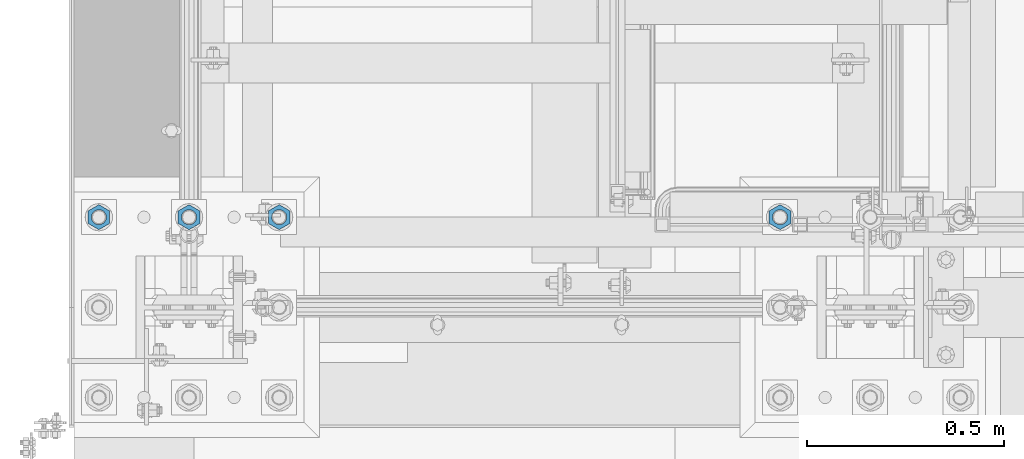
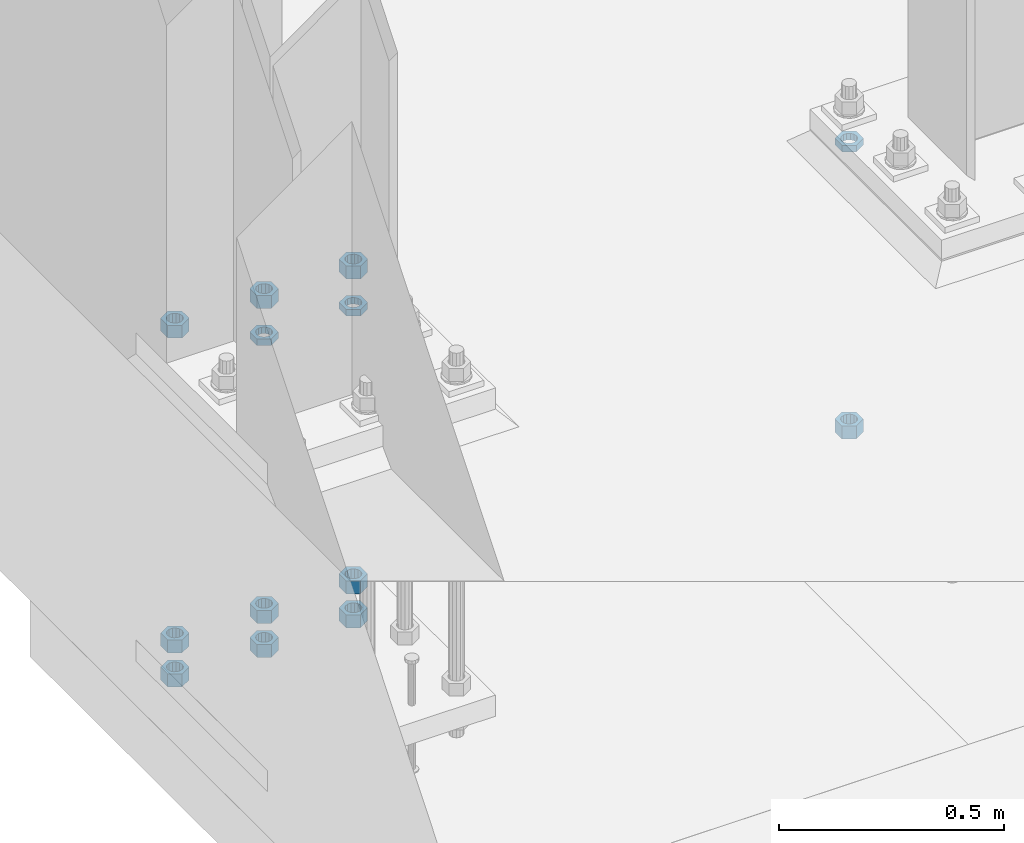
# One storey, part 1383 of 1876: 13 beams, 2 elements without a shape of their own.
"""IFC2X3 building model written with IfcOpenShell, lengths in millimetres."""

from ifc_helpers import new_model, si_unit, frame, origin_with_axes, place, context, subcontext, project, spatial, faceted_brep, material, type_object, element, aggregate, save


model = new_model("IFC2X3")

# Units and contexts
model_context = context("Model", 3, precision=1e-05, world=origin_with_axes())
body_context = subcontext(model_context, "Body", "Model", "MODEL_VIEW")
ifc_project = project(units=[si_unit("LENGTHUNIT", "METRE", prefix="MILLI"), si_unit("AREAUNIT", "SQUARE_METRE"), si_unit("VOLUMEUNIT", "CUBIC_METRE"), si_unit("MASSUNIT", "GRAM", prefix="KILO"), si_unit("TIMEUNIT", "SECOND"), si_unit("PLANEANGLEUNIT", "RADIAN"), si_unit("SOLIDANGLEUNIT", "STERADIAN"), si_unit("THERMODYNAMICTEMPERATUREUNIT", "DEGREE_CELSIUS"), si_unit("LUMINOUSINTENSITYUNIT", "LUMEN")], contexts=[model_context])

# Site, building, storey
site_placement = place(None, origin_with_axes())
site = spatial("IfcSite", under=ifc_project, at=site_placement, CompositionType="ELEMENT")
building_placement = place(site_placement, origin_with_axes())
building = spatial("IfcBuilding", under=site, at=building_placement, Name="Undefined", CompositionType="ELEMENT")
storey_placement = place(building_placement, origin_with_axes())
storey = spatial("IfcBuildingStorey", under=building, at=storey_placement, Name="Undefined", CompositionType="ELEMENT", Elevation=0.0)

# Assembly, beam
assembly_1_placement = place(storey_placement, origin_with_axes())
assembly_1 = element("IfcElementAssembly", 1, at=assembly_1_placement, inside=storey, Name="TEMPLATE", AssemblyPlace="NOTDEFINED", PredefinedType="RIGID_FRAME")
ifc_material = material(Name="STEEL/A563")
beam_type_1 = type_object("IfcBeamType", Name="1-3/8_DIA. HALF_NUT", PredefinedType="NOTDEFINED")
beam_1_placement = place(assembly_1_placement, frame((1498.6, -6883.4, 33.3375), z_axis=(-1.0, 0.0, 0.0), x_axis=(0.0, 0.0, -1.0)))
beam_1 = element("IfcBeam", 2, at=beam_1_placement, type_object=beam_type_1, material=ifc_material, Name="NUT", ObjectType="1-3/8_DIA. HALF_NUT", context=body_context, shape_type="Brep", body=[
    faceted_brep([(0.0, -31.75, 0.0), (0.0, -15.8800001144409, -27.5), (17.4625, -15.8800001144409, -27.5), (17.4625, -31.75, 0.0), (0.0, 15.8800001144409, -27.5), (17.4625, 15.8800001144409, -27.5), (0.0, 31.75, 0.0), (17.4625, 31.75, 0.0), (0.0, 15.8800001144409, 27.5), (17.4625, 15.8800001144409, 27.5), (0.0, -15.8800001144409, 27.5), (17.4625, -15.8800001144409, 27.5), (0.0, 0.0, 19.0499999999993), (0.0, 8.2654848991624, 17.1634562461559), (17.4625, 8.2654848991624, 17.1634562461559), (17.4625, 0.0, 19.0499992370605), (0.0, 14.8938891445259, 11.8774802497237), (17.4625, 14.8938891445259, 11.8774802497237), (0.0, 18.5723759832526, 4.2390236220981), (17.4625, 18.5723759832526, 4.2390236220981), (0.0, 18.5723759832526, -4.2390236220981), (17.4625, 18.5723759832526, -4.2390236220981), (0.0, 14.8938891445259, -11.8774802497237), (17.4625, 14.8938891445259, -11.8774802497237), (0.0, 8.2654848991624, -17.1634562461568), (17.4625, 8.2654848991624, -17.1634562461568), (0.0, 0.0, -19.05), (17.4625, 0.0, -19.0499992370605), (0.0, -8.2654848991624, -17.1634562461559), (17.4625, -8.2654848991624, -17.1634562461559), (0.0, -14.8938891445259, -11.8774802497237), (17.4625, -14.8938891445259, -11.8774802497237), (0.0, -18.5723759832526, -4.2390236220981), (17.4625, -18.5723759832526, -4.2390236220981), (0.0, -18.5723759832526, 4.2390236220981), (17.4625, -18.5723759832526, 4.2390236220981), (0.0, -14.8938891445259, 11.8774802497237), (17.4625, -14.8938891445259, 11.8774802497237), (0.0, -8.2654848991624, 17.1634562461568), (17.4625, -8.2654848991624, 17.1634562461568)], [[[0, 1, 2, 3]], [[1, 4, 5, 2]], [[4, 6, 7, 5]], [[6, 8, 9, 7]], [[8, 10, 11, 9]], [[10, 0, 3, 11]], [[12, 13, 14, 15]], [[13, 16, 17, 14]], [[16, 18, 19, 17]], [[18, 20, 21, 19]], [[20, 22, 23, 21]], [[22, 24, 25, 23]], [[24, 26, 27, 25]], [[26, 28, 29, 27]], [[28, 30, 31, 29]], [[30, 32, 33, 31]], [[32, 34, 35, 33]], [[34, 36, 37, 35]], [[36, 38, 39, 37]], [[38, 12, 15, 39]], [[5, 7, 9, 11, 3, 2], [17, 19, 21, 23, 25, 27, 29, 31, 33, 35, 37, 39, 15, 14]], [[10, 8, 6, 4, 1, 0], [38, 36, 34, 32, 30, 28, 26, 24, 22, 20, 18, 16, 13, 12]]]),
])

# Assembly, beams
assembly_2_placement = place(storey_placement, origin_with_axes())
assembly_2 = element("IfcElementAssembly", 3, at=assembly_2_placement, inside=storey, Name="TEMPLATE", AssemblyPlace="NOTDEFINED", PredefinedType="RIGID_FRAME")
beam_2_placement = place(assembly_2_placement, frame((-2.27373675443232e-13, -6883.4, 33.3375), z_axis=(-1.0, 0.0, 0.0), x_axis=(0.0, 0.0, -1.0)))
beam_2 = element("IfcBeam", 4, at=beam_2_placement, type_object=beam_type_1, material=ifc_material, Name="NUT", ObjectType="1-3/8_DIA. HALF_NUT", context=body_context, shape_type="Brep", body=[
    faceted_brep([(0.0, -31.75, 0.0), (0.0, -15.8800001144409, -27.5), (17.4625, -15.8800001144409, -27.5), (17.4625, -31.75, 0.0), (0.0, 15.8800001144409, -27.5), (17.4625, 15.8800001144409, -27.5), (0.0, 31.75, 0.0), (17.4625, 31.75, 0.0), (0.0, 15.8800001144409, 27.5), (17.4625, 15.8800001144409, 27.5), (0.0, -15.8800001144409, 27.5), (17.4625, -15.8800001144409, 27.5), (0.0, 0.0, 19.0499999999993), (0.0, 8.2654848991624, 17.1634562461559), (17.4625, 8.2654848991624, 17.1634562461559), (17.4625, 0.0, 19.0499992370605), (0.0, 14.8938891445259, 11.8774802497237), (17.4625, 14.8938891445259, 11.8774802497237), (0.0, 18.5723759832526, 4.2390236220981), (17.4625, 18.5723759832526, 4.2390236220981), (0.0, 18.5723759832526, -4.2390236220981), (17.4625, 18.5723759832526, -4.2390236220981), (0.0, 14.8938891445259, -11.8774802497237), (17.4625, 14.8938891445259, -11.8774802497237), (0.0, 8.2654848991624, -17.1634562461568), (17.4625, 8.2654848991624, -17.1634562461568), (0.0, 0.0, -19.05), (17.4625, 0.0, -19.0499992370605), (0.0, -8.2654848991624, -17.1634562461559), (17.4625, -8.2654848991624, -17.1634562461559), (0.0, -14.8938891445259, -11.8774802497237), (17.4625, -14.8938891445259, -11.8774802497237), (0.0, -18.5723759832526, -4.2390236220981), (17.4625, -18.5723759832526, -4.2390236220981), (0.0, -18.5723759832526, 4.2390236220981), (17.4625, -18.5723759832526, 4.2390236220981), (0.0, -14.8938891445259, 11.8774802497237), (17.4625, -14.8938891445259, 11.8774802497237), (0.0, -8.2654848991624, 17.1634562461568), (17.4625, -8.2654848991624, 17.1634562461568)], [[[0, 1, 2, 3]], [[1, 4, 5, 2]], [[4, 6, 7, 5]], [[6, 8, 9, 7]], [[8, 10, 11, 9]], [[10, 0, 3, 11]], [[12, 13, 14, 15]], [[13, 16, 17, 14]], [[16, 18, 19, 17]], [[18, 20, 21, 19]], [[20, 22, 23, 21]], [[22, 24, 25, 23]], [[24, 26, 27, 25]], [[26, 28, 29, 27]], [[28, 30, 31, 29]], [[30, 32, 33, 31]], [[32, 34, 35, 33]], [[34, 36, 37, 35]], [[36, 38, 39, 37]], [[38, 12, 15, 39]], [[5, 7, 9, 11, 3, 2], [17, 19, 21, 23, 25, 27, 29, 31, 33, 35, 37, 39, 15, 14]], [[10, 8, 6, 4, 1, 0], [38, 36, 34, 32, 30, 28, 26, 24, 22, 20, 18, 16, 13, 12]]]),
])
beam_3_placement = place(assembly_2_placement, frame((228.6, -6883.4, 33.3375), z_axis=(-1.0, 0.0, 0.0), x_axis=(0.0, 0.0, -1.0)))
beam_3 = element("IfcBeam", 5, at=beam_3_placement, type_object=beam_type_1, material=ifc_material, Name="NUT", ObjectType="1-3/8_DIA. HALF_NUT", context=body_context, shape_type="Brep", body=[
    faceted_brep([(0.0, -31.75, 0.0), (0.0, -15.8800001144409, -27.5), (17.4625, -15.8800001144409, -27.5), (17.4625, -31.75, 0.0), (0.0, 15.8800001144409, -27.5), (17.4625, 15.8800001144409, -27.5), (0.0, 31.75, 0.0), (17.4625, 31.75, 0.0), (0.0, 15.8800001144409, 27.5), (17.4625, 15.8800001144409, 27.5), (0.0, -15.8800001144409, 27.5), (17.4625, -15.8800001144409, 27.5), (0.0, 0.0, 19.0499999999993), (0.0, 8.2654848991624, 17.1634562461559), (17.4625, 8.2654848991624, 17.1634562461559), (17.4625, 0.0, 19.0499992370605), (0.0, 14.8938891445259, 11.8774802497237), (17.4625, 14.8938891445259, 11.8774802497237), (0.0, 18.5723759832526, 4.2390236220981), (17.4625, 18.5723759832526, 4.2390236220981), (0.0, 18.5723759832526, -4.2390236220981), (17.4625, 18.5723759832526, -4.2390236220981), (0.0, 14.8938891445259, -11.8774802497237), (17.4625, 14.8938891445259, -11.8774802497237), (0.0, 8.2654848991624, -17.1634562461568), (17.4625, 8.2654848991624, -17.1634562461568), (0.0, 0.0, -19.05), (17.4625, 0.0, -19.0499992370605), (0.0, -8.2654848991624, -17.1634562461559), (17.4625, -8.2654848991624, -17.1634562461559), (0.0, -14.8938891445259, -11.8774802497237), (17.4625, -14.8938891445259, -11.8774802497237), (0.0, -18.5723759832526, -4.2390236220981), (17.4625, -18.5723759832526, -4.2390236220981), (0.0, -18.5723759832526, 4.2390236220981), (17.4625, -18.5723759832526, 4.2390236220981), (0.0, -14.8938891445259, 11.8774802497237), (17.4625, -14.8938891445259, 11.8774802497237), (0.0, -8.2654848991624, 17.1634562461568), (17.4625, -8.2654848991624, 17.1634562461568)], [[[0, 1, 2, 3]], [[1, 4, 5, 2]], [[4, 6, 7, 5]], [[6, 8, 9, 7]], [[8, 10, 11, 9]], [[10, 0, 3, 11]], [[12, 13, 14, 15]], [[13, 16, 17, 14]], [[16, 18, 19, 17]], [[18, 20, 21, 19]], [[20, 22, 23, 21]], [[22, 24, 25, 23]], [[24, 26, 27, 25]], [[26, 28, 29, 27]], [[28, 30, 31, 29]], [[30, 32, 33, 31]], [[32, 34, 35, 33]], [[34, 36, 37, 35]], [[36, 38, 39, 37]], [[38, 12, 15, 39]], [[5, 7, 9, 11, 3, 2], [17, 19, 21, 23, 25, 27, 29, 31, 33, 35, 37, 39, 15, 14]], [[10, 8, 6, 4, 1, 0], [38, 36, 34, 32, 30, 28, 26, 24, 22, 20, 18, 16, 13, 12]]]),
])

# Beam
beam_type_2 = type_object("IfcBeamType", Name="1-3/8_HEAVY_HEX_NUT", PredefinedType="NOTDEFINED")
beam_4_placement = place(assembly_1_placement, frame((1498.60001220703, -6883.4, -727.074998474121), z_axis=(-1.0, 0.0, 0.0), x_axis=(0.0, 0.0, -1.0)))
beam_4 = element("IfcBeam", 6, at=beam_4_placement, type_object=beam_type_2, material=ifc_material, Name="NUT", ObjectType="1-3/8_HEAVY_HEX_NUT", context=body_context, shape_type="Brep", body=[
    faceted_brep([(0.0, -31.75, 0.0), (0.0, -15.8800001144409, -27.5), (34.925, -15.8800001144409, -27.5), (34.925, -31.75, 0.0), (0.0, 15.8800001144409, -27.5), (34.925, 15.8800001144409, -27.5), (0.0, 31.75, 0.0), (34.925, 31.75, 0.0), (0.0, 15.8800001144409, 27.5), (34.925, 15.8800001144409, 27.5), (0.0, -15.8800001144409, 27.5), (34.925, -15.8800001144409, 27.5), (0.0, 0.0, 19.0499999999993), (0.0, 8.2654848991624, 17.1634562461559), (34.925, 8.26548489916252, 17.163456246155), (34.925, 0.0, 19.0499992370605), (0.0, 14.8938891445259, 11.8774802497237), (34.925, 14.8938891445259, 11.8774802497246), (0.0, 18.5723759832526, 4.2390236220981), (34.925, 18.5723759832528, 4.23902362209628), (0.0, 18.5723759832526, -4.2390236220981), (34.925, 18.5723759832528, -4.23902362209628), (0.0, 14.8938891445259, -11.8774802497237), (34.925, 14.8938891445259, -11.8774802497246), (0.0, 8.2654848991624, -17.1634562461568), (34.925, 8.26548489916252, -17.163456246155), (0.0, 0.0, -19.05), (34.925, 0.0, -19.0499992370605), (0.0, -8.2654848991624, -17.1634562461559), (34.925, -8.26548489916252, -17.163456246155), (0.0, -14.8938891445259, -11.8774802497237), (34.925, -14.8938891445259, -11.8774802497246), (0.0, -18.5723759832526, -4.2390236220981), (34.925, -18.5723759832528, -4.23902362209628), (0.0, -18.5723759832526, 4.2390236220981), (34.925, -18.5723759832528, 4.23902362209628), (0.0, -14.8938891445259, 11.8774802497237), (34.925, -14.8938891445259, 11.8774802497246), (0.0, -8.2654848991624, 17.1634562461568), (34.925, -8.26548489916252, 17.163456246155)], [[[0, 1, 2, 3]], [[1, 4, 5, 2]], [[4, 6, 7, 5]], [[6, 8, 9, 7]], [[8, 10, 11, 9]], [[10, 0, 3, 11]], [[12, 13, 14, 15]], [[13, 16, 17, 14]], [[16, 18, 19, 17]], [[18, 20, 21, 19]], [[20, 22, 23, 21]], [[22, 24, 25, 23]], [[24, 26, 27, 25]], [[26, 28, 29, 27]], [[28, 30, 31, 29]], [[30, 32, 33, 31]], [[32, 34, 35, 33]], [[34, 36, 37, 35]], [[36, 38, 39, 37]], [[38, 12, 15, 39]], [[5, 7, 9, 11, 3, 2], [17, 19, 21, 23, 25, 27, 29, 31, 33, 35, 37, 39, 15, 14]], [[10, 8, 6, 4, 1, 0], [38, 36, 34, 32, 30, 28, 26, 24, 22, 20, 18, 16, 13, 12]]]),
])

aggregate(assembly_1, [beam_1, beam_4])

beam_5_placement = place(assembly_2_placement, frame((228.600012207031, -6883.4, -701.674998474121), z_axis=(-1.0, 0.0, 0.0), x_axis=(0.0, 0.0, -1.0)))
beam_5 = element("IfcBeam", 7, at=beam_5_placement, type_object=beam_type_2, material=ifc_material, Name="NUT", ObjectType="1-3/8_HEAVY_HEX_NUT", context=body_context, shape_type="Brep", body=[
    faceted_brep([(0.0, -31.75, 0.0), (0.0, -15.8800001144409, -27.5), (34.925, -15.8800001144409, -27.5), (34.925, -31.75, 0.0), (0.0, 15.8800001144409, -27.5), (34.925, 15.8800001144409, -27.5), (0.0, 31.75, 0.0), (34.925, 31.75, 0.0), (0.0, 15.8800001144409, 27.5), (34.925, 15.8800001144409, 27.5), (0.0, -15.8800001144409, 27.5), (34.925, -15.8800001144409, 27.5), (0.0, 0.0, 19.0499999999993), (0.0, 8.2654848991624, 17.1634562461559), (34.925, 8.26548489916252, 17.163456246155), (34.925, 0.0, 19.0499992370605), (0.0, 14.8938891445259, 11.8774802497237), (34.925, 14.8938891445259, 11.8774802497246), (0.0, 18.5723759832526, 4.2390236220981), (34.925, 18.5723759832528, 4.23902362209628), (0.0, 18.5723759832526, -4.2390236220981), (34.925, 18.5723759832528, -4.23902362209628), (0.0, 14.8938891445259, -11.8774802497237), (34.925, 14.8938891445259, -11.8774802497246), (0.0, 8.2654848991624, -17.1634562461568), (34.925, 8.26548489916252, -17.163456246155), (0.0, 0.0, -19.05), (34.925, 0.0, -19.0499992370605), (0.0, -8.2654848991624, -17.1634562461559), (34.925, -8.26548489916252, -17.163456246155), (0.0, -14.8938891445259, -11.8774802497237), (34.925, -14.8938891445259, -11.8774802497246), (0.0, -18.5723759832526, -4.2390236220981), (34.925, -18.5723759832528, -4.23902362209628), (0.0, -18.5723759832526, 4.2390236220981), (34.925, -18.5723759832528, 4.23902362209628), (0.0, -14.8938891445259, 11.8774802497237), (34.925, -14.8938891445259, 11.8774802497246), (0.0, -8.2654848991624, 17.1634562461568), (34.925, -8.26548489916252, 17.163456246155)], [[[0, 1, 2, 3]], [[1, 4, 5, 2]], [[4, 6, 7, 5]], [[6, 8, 9, 7]], [[8, 10, 11, 9]], [[10, 0, 3, 11]], [[12, 13, 14, 15]], [[13, 16, 17, 14]], [[16, 18, 19, 17]], [[18, 20, 21, 19]], [[20, 22, 23, 21]], [[22, 24, 25, 23]], [[24, 26, 27, 25]], [[26, 28, 29, 27]], [[28, 30, 31, 29]], [[30, 32, 33, 31]], [[32, 34, 35, 33]], [[34, 36, 37, 35]], [[36, 38, 39, 37]], [[38, 12, 15, 39]], [[5, 7, 9, 11, 3, 2], [17, 19, 21, 23, 25, 27, 29, 31, 33, 35, 37, 39, 15, 14]], [[10, 8, 6, 4, 1, 0], [38, 36, 34, 32, 30, 28, 26, 24, 22, 20, 18, 16, 13, 12]]]),
])

beam_6_placement = place(assembly_2_placement, frame((1.22070313182121e-05, -6883.4, -701.674998474121), z_axis=(-1.0, 0.0, 0.0), x_axis=(0.0, 0.0, -1.0)))
beam_6 = element("IfcBeam", 8, at=beam_6_placement, type_object=beam_type_2, material=ifc_material, Name="NUT", ObjectType="1-3/8_HEAVY_HEX_NUT", context=body_context, shape_type="Brep", body=[
    faceted_brep([(0.0, -31.75, 0.0), (0.0, -15.8800001144409, -27.5), (34.925, -15.8800001144409, -27.5), (34.925, -31.75, 0.0), (0.0, 15.8800001144409, -27.5), (34.925, 15.8800001144409, -27.5), (0.0, 31.75, 0.0), (34.925, 31.75, 0.0), (0.0, 15.8800001144409, 27.5), (34.925, 15.8800001144409, 27.5), (0.0, -15.8800001144409, 27.5), (34.925, -15.8800001144409, 27.5), (0.0, 0.0, 19.0499999999993), (0.0, 8.2654848991624, 17.1634562461559), (34.925, 8.26548489916252, 17.163456246155), (34.925, 0.0, 19.0499992370605), (0.0, 14.8938891445259, 11.8774802497237), (34.925, 14.8938891445259, 11.8774802497246), (0.0, 18.5723759832526, 4.2390236220981), (34.925, 18.5723759832528, 4.23902362209628), (0.0, 18.5723759832526, -4.2390236220981), (34.925, 18.5723759832528, -4.23902362209628), (0.0, 14.8938891445259, -11.8774802497237), (34.925, 14.8938891445259, -11.8774802497246), (0.0, 8.2654848991624, -17.1634562461568), (34.925, 8.26548489916252, -17.163456246155), (0.0, 0.0, -19.05), (34.925, 0.0, -19.0499992370605), (0.0, -8.2654848991624, -17.1634562461559), (34.925, -8.26548489916252, -17.163456246155), (0.0, -14.8938891445259, -11.8774802497237), (34.925, -14.8938891445259, -11.8774802497246), (0.0, -18.5723759832526, -4.2390236220981), (34.925, -18.5723759832528, -4.23902362209628), (0.0, -18.5723759832526, 4.2390236220981), (34.925, -18.5723759832528, 4.23902362209628), (0.0, -14.8938891445259, 11.8774802497237), (34.925, -14.8938891445259, 11.8774802497246), (0.0, -8.2654848991624, 17.1634562461568), (34.925, -8.26548489916252, 17.163456246155)], [[[0, 1, 2, 3]], [[1, 4, 5, 2]], [[4, 6, 7, 5]], [[6, 8, 9, 7]], [[8, 10, 11, 9]], [[10, 0, 3, 11]], [[12, 13, 14, 15]], [[13, 16, 17, 14]], [[16, 18, 19, 17]], [[18, 20, 21, 19]], [[20, 22, 23, 21]], [[22, 24, 25, 23]], [[24, 26, 27, 25]], [[26, 28, 29, 27]], [[28, 30, 31, 29]], [[30, 32, 33, 31]], [[32, 34, 35, 33]], [[34, 36, 37, 35]], [[36, 38, 39, 37]], [[38, 12, 15, 39]], [[5, 7, 9, 11, 3, 2], [17, 19, 21, 23, 25, 27, 29, 31, 33, 35, 37, 39, 15, 14]], [[10, 8, 6, 4, 1, 0], [38, 36, 34, 32, 30, 28, 26, 24, 22, 20, 18, 16, 13, 12]]]),
])

beam_7_placement = place(assembly_2_placement, frame((-228.599987792969, -6883.4, -701.674998474121), z_axis=(-1.0, 0.0, 0.0), x_axis=(0.0, 0.0, -1.0)))
beam_7 = element("IfcBeam", 9, at=beam_7_placement, type_object=beam_type_2, material=ifc_material, Name="NUT", ObjectType="1-3/8_HEAVY_HEX_NUT", context=body_context, shape_type="Brep", body=[
    faceted_brep([(0.0, -31.75, 0.0), (0.0, -15.8800001144409, -27.5), (34.925, -15.8800001144409, -27.5), (34.925, -31.75, 0.0), (0.0, 15.8800001144409, -27.5), (34.925, 15.8800001144409, -27.5), (0.0, 31.75, 0.0), (34.925, 31.75, 0.0), (0.0, 15.8800001144409, 27.5), (34.925, 15.8800001144409, 27.5), (0.0, -15.8800001144409, 27.5), (34.925, -15.8800001144409, 27.5), (0.0, 0.0, 19.0499999999993), (0.0, 8.2654848991624, 17.1634562461559), (34.925, 8.26548489916252, 17.163456246155), (34.925, 0.0, 19.0499992370605), (0.0, 14.8938891445259, 11.8774802497237), (34.925, 14.8938891445259, 11.8774802497246), (0.0, 18.5723759832526, 4.2390236220981), (34.925, 18.5723759832528, 4.23902362209628), (0.0, 18.5723759832526, -4.2390236220981), (34.925, 18.5723759832528, -4.23902362209628), (0.0, 14.8938891445259, -11.8774802497237), (34.925, 14.8938891445259, -11.8774802497246), (0.0, 8.2654848991624, -17.1634562461568), (34.925, 8.26548489916252, -17.163456246155), (0.0, 0.0, -19.05), (34.925, 0.0, -19.0499992370605), (0.0, -8.2654848991624, -17.1634562461559), (34.925, -8.26548489916252, -17.163456246155), (0.0, -14.8938891445259, -11.8774802497237), (34.925, -14.8938891445259, -11.8774802497246), (0.0, -18.5723759832526, -4.2390236220981), (34.925, -18.5723759832528, -4.23902362209628), (0.0, -18.5723759832526, 4.2390236220981), (34.925, -18.5723759832528, 4.23902362209628), (0.0, -14.8938891445259, 11.8774802497237), (34.925, -14.8938891445259, 11.8774802497246), (0.0, -8.2654848991624, 17.1634562461568), (34.925, -8.26548489916252, 17.163456246155)], [[[0, 1, 2, 3]], [[1, 4, 5, 2]], [[4, 6, 7, 5]], [[6, 8, 9, 7]], [[8, 10, 11, 9]], [[10, 0, 3, 11]], [[12, 13, 14, 15]], [[13, 16, 17, 14]], [[16, 18, 19, 17]], [[18, 20, 21, 19]], [[20, 22, 23, 21]], [[22, 24, 25, 23]], [[24, 26, 27, 25]], [[26, 28, 29, 27]], [[28, 30, 31, 29]], [[30, 32, 33, 31]], [[32, 34, 35, 33]], [[34, 36, 37, 35]], [[36, 38, 39, 37]], [[38, 12, 15, 39]], [[5, 7, 9, 11, 3, 2], [17, 19, 21, 23, 25, 27, 29, 31, 33, 35, 37, 39, 15, 14]], [[10, 8, 6, 4, 1, 0], [38, 36, 34, 32, 30, 28, 26, 24, 22, 20, 18, 16, 13, 12]]]),
])

beam_8_placement = place(assembly_2_placement, frame((228.6, -6883.4, 150.8125), z_axis=(-1.0, 0.0, 0.0), x_axis=(0.0, 0.0, -1.0)))
beam_8 = element("IfcBeam", 10, at=beam_8_placement, type_object=beam_type_2, material=ifc_material, Name="NUT", ObjectType="1-3/8_HEAVY_HEX_NUT", context=body_context, shape_type="Brep", body=[
    faceted_brep([(0.0, -31.75, 0.0), (0.0, -15.8800001144409, -27.5), (34.925, -15.8800001144409, -27.5), (34.925, -31.75, 0.0), (0.0, 15.8800001144409, -27.5), (34.925, 15.8800001144409, -27.5), (0.0, 31.75, 0.0), (34.925, 31.75, 0.0), (0.0, 15.8800001144409, 27.5), (34.925, 15.8800001144409, 27.5), (0.0, -15.8800001144409, 27.5), (34.925, -15.8800001144409, 27.5), (0.0, 0.0, 19.0499999999993), (0.0, 8.2654848991624, 17.1634562461559), (34.925, 8.26548489916252, 17.163456246155), (34.925, 0.0, 19.0499992370605), (0.0, 14.8938891445259, 11.8774802497237), (34.925, 14.8938891445259, 11.8774802497246), (0.0, 18.5723759832526, 4.2390236220981), (34.925, 18.5723759832528, 4.23902362209628), (0.0, 18.5723759832526, -4.2390236220981), (34.925, 18.5723759832528, -4.23902362209628), (0.0, 14.8938891445259, -11.8774802497237), (34.925, 14.8938891445259, -11.8774802497246), (0.0, 8.2654848991624, -17.1634562461568), (34.925, 8.26548489916252, -17.163456246155), (0.0, 0.0, -19.05), (34.925, 0.0, -19.0499992370605), (0.0, -8.2654848991624, -17.1634562461559), (34.925, -8.26548489916252, -17.163456246155), (0.0, -14.8938891445259, -11.8774802497237), (34.925, -14.8938891445259, -11.8774802497246), (0.0, -18.5723759832526, -4.2390236220981), (34.925, -18.5723759832528, -4.23902362209628), (0.0, -18.5723759832526, 4.2390236220981), (34.925, -18.5723759832528, 4.23902362209628), (0.0, -14.8938891445259, 11.8774802497237), (34.925, -14.8938891445259, 11.8774802497246), (0.0, -8.2654848991624, 17.1634562461568), (34.925, -8.26548489916252, 17.163456246155)], [[[0, 1, 2, 3]], [[1, 4, 5, 2]], [[4, 6, 7, 5]], [[6, 8, 9, 7]], [[8, 10, 11, 9]], [[10, 0, 3, 11]], [[12, 13, 14, 15]], [[13, 16, 17, 14]], [[16, 18, 19, 17]], [[18, 20, 21, 19]], [[20, 22, 23, 21]], [[22, 24, 25, 23]], [[24, 26, 27, 25]], [[26, 28, 29, 27]], [[28, 30, 31, 29]], [[30, 32, 33, 31]], [[32, 34, 35, 33]], [[34, 36, 37, 35]], [[36, 38, 39, 37]], [[38, 12, 15, 39]], [[5, 7, 9, 11, 3, 2], [17, 19, 21, 23, 25, 27, 29, 31, 33, 35, 37, 39, 15, 14]], [[10, 8, 6, 4, 1, 0], [38, 36, 34, 32, 30, 28, 26, 24, 22, 20, 18, 16, 13, 12]]]),
])

beam_9_placement = place(assembly_2_placement, frame((228.6, -6883.4, -793.75), z_axis=(-1.0, 0.0, 0.0), x_axis=(0.0, 0.0, -1.0)))
beam_9 = element("IfcBeam", 11, at=beam_9_placement, type_object=beam_type_2, material=ifc_material, Name="NUT", ObjectType="1-3/8_HEAVY_HEX_NUT", context=body_context, shape_type="Brep", body=[
    faceted_brep([(0.0, -31.75, 0.0), (0.0, -15.8800001144409, -27.5), (34.925, -15.8800001144409, -27.5), (34.925, -31.75, 0.0), (0.0, 15.8800001144409, -27.5), (34.925, 15.8800001144409, -27.5), (0.0, 31.75, 0.0), (34.925, 31.75, 0.0), (0.0, 15.8800001144409, 27.5), (34.925, 15.8800001144409, 27.5), (0.0, -15.8800001144409, 27.5), (34.925, -15.8800001144409, 27.5), (0.0, 0.0, 19.0499999999993), (0.0, 8.2654848991624, 17.1634562461559), (34.925, 8.26548489916252, 17.163456246155), (34.925, 0.0, 19.0499992370605), (0.0, 14.8938891445259, 11.8774802497237), (34.925, 14.8938891445259, 11.8774802497246), (0.0, 18.5723759832526, 4.2390236220981), (34.925, 18.5723759832528, 4.23902362209628), (0.0, 18.5723759832526, -4.2390236220981), (34.925, 18.5723759832528, -4.23902362209628), (0.0, 14.8938891445259, -11.8774802497237), (34.925, 14.8938891445259, -11.8774802497246), (0.0, 8.2654848991624, -17.1634562461568), (34.925, 8.26548489916252, -17.163456246155), (0.0, 0.0, -19.05), (34.925, 0.0, -19.0499992370605), (0.0, -8.2654848991624, -17.1634562461559), (34.925, -8.26548489916252, -17.163456246155), (0.0, -14.8938891445259, -11.8774802497237), (34.925, -14.8938891445259, -11.8774802497246), (0.0, -18.5723759832526, -4.2390236220981), (34.925, -18.5723759832528, -4.23902362209628), (0.0, -18.5723759832526, 4.2390236220981), (34.925, -18.5723759832528, 4.23902362209628), (0.0, -14.8938891445259, 11.8774802497237), (34.925, -14.8938891445259, 11.8774802497246), (0.0, -8.2654848991624, 17.1634562461568), (34.925, -8.26548489916252, 17.163456246155)], [[[0, 1, 2, 3]], [[1, 4, 5, 2]], [[4, 6, 7, 5]], [[6, 8, 9, 7]], [[8, 10, 11, 9]], [[10, 0, 3, 11]], [[12, 13, 14, 15]], [[13, 16, 17, 14]], [[16, 18, 19, 17]], [[18, 20, 21, 19]], [[20, 22, 23, 21]], [[22, 24, 25, 23]], [[24, 26, 27, 25]], [[26, 28, 29, 27]], [[28, 30, 31, 29]], [[30, 32, 33, 31]], [[32, 34, 35, 33]], [[34, 36, 37, 35]], [[36, 38, 39, 37]], [[38, 12, 15, 39]], [[5, 7, 9, 11, 3, 2], [17, 19, 21, 23, 25, 27, 29, 31, 33, 35, 37, 39, 15, 14]], [[10, 8, 6, 4, 1, 0], [38, 36, 34, 32, 30, 28, 26, 24, 22, 20, 18, 16, 13, 12]]]),
])

beam_10_placement = place(assembly_2_placement, frame((-1.13686837721616e-13, -6883.4, 150.8125), z_axis=(-1.0, 0.0, 0.0), x_axis=(0.0, 0.0, -1.0)))
beam_10 = element("IfcBeam", 12, at=beam_10_placement, type_object=beam_type_2, material=ifc_material, Name="NUT", ObjectType="1-3/8_HEAVY_HEX_NUT", context=body_context, shape_type="Brep", body=[
    faceted_brep([(0.0, -31.75, 0.0), (0.0, -15.8800001144409, -27.5), (34.925, -15.8800001144409, -27.5), (34.925, -31.75, 0.0), (0.0, 15.8800001144409, -27.5), (34.925, 15.8800001144409, -27.5), (0.0, 31.75, 0.0), (34.925, 31.75, 0.0), (0.0, 15.8800001144409, 27.5), (34.925, 15.8800001144409, 27.5), (0.0, -15.8800001144409, 27.5), (34.925, -15.8800001144409, 27.5), (0.0, 0.0, 19.0499999999993), (0.0, 8.2654848991624, 17.1634562461559), (34.925, 8.26548489916252, 17.163456246155), (34.925, 0.0, 19.0499992370605), (0.0, 14.8938891445259, 11.8774802497237), (34.925, 14.8938891445259, 11.8774802497246), (0.0, 18.5723759832526, 4.2390236220981), (34.925, 18.5723759832528, 4.23902362209628), (0.0, 18.5723759832526, -4.2390236220981), (34.925, 18.5723759832528, -4.23902362209628), (0.0, 14.8938891445259, -11.8774802497237), (34.925, 14.8938891445259, -11.8774802497246), (0.0, 8.2654848991624, -17.1634562461568), (34.925, 8.26548489916252, -17.163456246155), (0.0, 0.0, -19.05), (34.925, 0.0, -19.0499992370605), (0.0, -8.2654848991624, -17.1634562461559), (34.925, -8.26548489916252, -17.163456246155), (0.0, -14.8938891445259, -11.8774802497237), (34.925, -14.8938891445259, -11.8774802497246), (0.0, -18.5723759832526, -4.2390236220981), (34.925, -18.5723759832528, -4.23902362209628), (0.0, -18.5723759832526, 4.2390236220981), (34.925, -18.5723759832528, 4.23902362209628), (0.0, -14.8938891445259, 11.8774802497237), (34.925, -14.8938891445259, 11.8774802497246), (0.0, -8.2654848991624, 17.1634562461568), (34.925, -8.26548489916252, 17.163456246155)], [[[0, 1, 2, 3]], [[1, 4, 5, 2]], [[4, 6, 7, 5]], [[6, 8, 9, 7]], [[8, 10, 11, 9]], [[10, 0, 3, 11]], [[12, 13, 14, 15]], [[13, 16, 17, 14]], [[16, 18, 19, 17]], [[18, 20, 21, 19]], [[20, 22, 23, 21]], [[22, 24, 25, 23]], [[24, 26, 27, 25]], [[26, 28, 29, 27]], [[28, 30, 31, 29]], [[30, 32, 33, 31]], [[32, 34, 35, 33]], [[34, 36, 37, 35]], [[36, 38, 39, 37]], [[38, 12, 15, 39]], [[5, 7, 9, 11, 3, 2], [17, 19, 21, 23, 25, 27, 29, 31, 33, 35, 37, 39, 15, 14]], [[10, 8, 6, 4, 1, 0], [38, 36, 34, 32, 30, 28, 26, 24, 22, 20, 18, 16, 13, 12]]]),
])

beam_11_placement = place(assembly_2_placement, frame((-1.13686837721616e-13, -6883.4, -793.75), z_axis=(-1.0, 0.0, 0.0), x_axis=(0.0, 0.0, -1.0)))
beam_11 = element("IfcBeam", 13, at=beam_11_placement, type_object=beam_type_2, material=ifc_material, Name="NUT", ObjectType="1-3/8_HEAVY_HEX_NUT", context=body_context, shape_type="Brep", body=[
    faceted_brep([(0.0, -31.75, 0.0), (0.0, -15.8800001144409, -27.5), (34.925, -15.8800001144409, -27.5), (34.925, -31.75, 0.0), (0.0, 15.8800001144409, -27.5), (34.925, 15.8800001144409, -27.5), (0.0, 31.75, 0.0), (34.925, 31.75, 0.0), (0.0, 15.8800001144409, 27.5), (34.925, 15.8800001144409, 27.5), (0.0, -15.8800001144409, 27.5), (34.925, -15.8800001144409, 27.5), (0.0, 0.0, 19.0499999999993), (0.0, 8.2654848991624, 17.1634562461559), (34.925, 8.26548489916252, 17.163456246155), (34.925, 0.0, 19.0499992370605), (0.0, 14.8938891445259, 11.8774802497237), (34.925, 14.8938891445259, 11.8774802497246), (0.0, 18.5723759832526, 4.2390236220981), (34.925, 18.5723759832528, 4.23902362209628), (0.0, 18.5723759832526, -4.2390236220981), (34.925, 18.5723759832528, -4.23902362209628), (0.0, 14.8938891445259, -11.8774802497237), (34.925, 14.8938891445259, -11.8774802497246), (0.0, 8.2654848991624, -17.1634562461568), (34.925, 8.26548489916252, -17.163456246155), (0.0, 0.0, -19.05), (34.925, 0.0, -19.0499992370605), (0.0, -8.2654848991624, -17.1634562461559), (34.925, -8.26548489916252, -17.163456246155), (0.0, -14.8938891445259, -11.8774802497237), (34.925, -14.8938891445259, -11.8774802497246), (0.0, -18.5723759832526, -4.2390236220981), (34.925, -18.5723759832528, -4.23902362209628), (0.0, -18.5723759832526, 4.2390236220981), (34.925, -18.5723759832528, 4.23902362209628), (0.0, -14.8938891445259, 11.8774802497237), (34.925, -14.8938891445259, 11.8774802497246), (0.0, -8.2654848991624, 17.1634562461568), (34.925, -8.26548489916252, 17.163456246155)], [[[0, 1, 2, 3]], [[1, 4, 5, 2]], [[4, 6, 7, 5]], [[6, 8, 9, 7]], [[8, 10, 11, 9]], [[10, 0, 3, 11]], [[12, 13, 14, 15]], [[13, 16, 17, 14]], [[16, 18, 19, 17]], [[18, 20, 21, 19]], [[20, 22, 23, 21]], [[22, 24, 25, 23]], [[24, 26, 27, 25]], [[26, 28, 29, 27]], [[28, 30, 31, 29]], [[30, 32, 33, 31]], [[32, 34, 35, 33]], [[34, 36, 37, 35]], [[36, 38, 39, 37]], [[38, 12, 15, 39]], [[5, 7, 9, 11, 3, 2], [17, 19, 21, 23, 25, 27, 29, 31, 33, 35, 37, 39, 15, 14]], [[10, 8, 6, 4, 1, 0], [38, 36, 34, 32, 30, 28, 26, 24, 22, 20, 18, 16, 13, 12]]]),
])

beam_12_placement = place(assembly_2_placement, frame((-228.6, -6883.4, 150.8125), z_axis=(-1.0, 0.0, 0.0), x_axis=(0.0, 0.0, -1.0)))
beam_12 = element("IfcBeam", 14, at=beam_12_placement, type_object=beam_type_2, material=ifc_material, Name="NUT", ObjectType="1-3/8_HEAVY_HEX_NUT", context=body_context, shape_type="Brep", body=[
    faceted_brep([(0.0, -31.75, 0.0), (0.0, -15.8800001144409, -27.5), (34.925, -15.8800001144409, -27.5), (34.925, -31.75, 0.0), (0.0, 15.8800001144409, -27.5), (34.925, 15.8800001144409, -27.5), (0.0, 31.75, 0.0), (34.925, 31.75, 0.0), (0.0, 15.8800001144409, 27.5), (34.925, 15.8800001144409, 27.5), (0.0, -15.8800001144409, 27.5), (34.925, -15.8800001144409, 27.5), (0.0, 0.0, 19.0499999999993), (0.0, 8.2654848991624, 17.1634562461559), (34.925, 8.26548489916252, 17.163456246155), (34.925, 0.0, 19.0499992370605), (0.0, 14.8938891445259, 11.8774802497237), (34.925, 14.8938891445259, 11.8774802497246), (0.0, 18.5723759832526, 4.2390236220981), (34.925, 18.5723759832528, 4.23902362209628), (0.0, 18.5723759832526, -4.2390236220981), (34.925, 18.5723759832528, -4.23902362209628), (0.0, 14.8938891445259, -11.8774802497237), (34.925, 14.8938891445259, -11.8774802497246), (0.0, 8.2654848991624, -17.1634562461568), (34.925, 8.26548489916252, -17.163456246155), (0.0, 0.0, -19.05), (34.925, 0.0, -19.0499992370605), (0.0, -8.2654848991624, -17.1634562461559), (34.925, -8.26548489916252, -17.163456246155), (0.0, -14.8938891445259, -11.8774802497237), (34.925, -14.8938891445259, -11.8774802497246), (0.0, -18.5723759832526, -4.2390236220981), (34.925, -18.5723759832528, -4.23902362209628), (0.0, -18.5723759832526, 4.2390236220981), (34.925, -18.5723759832528, 4.23902362209628), (0.0, -14.8938891445259, 11.8774802497237), (34.925, -14.8938891445259, 11.8774802497246), (0.0, -8.2654848991624, 17.1634562461568), (34.925, -8.26548489916252, 17.163456246155)], [[[0, 1, 2, 3]], [[1, 4, 5, 2]], [[4, 6, 7, 5]], [[6, 8, 9, 7]], [[8, 10, 11, 9]], [[10, 0, 3, 11]], [[12, 13, 14, 15]], [[13, 16, 17, 14]], [[16, 18, 19, 17]], [[18, 20, 21, 19]], [[20, 22, 23, 21]], [[22, 24, 25, 23]], [[24, 26, 27, 25]], [[26, 28, 29, 27]], [[28, 30, 31, 29]], [[30, 32, 33, 31]], [[32, 34, 35, 33]], [[34, 36, 37, 35]], [[36, 38, 39, 37]], [[38, 12, 15, 39]], [[5, 7, 9, 11, 3, 2], [17, 19, 21, 23, 25, 27, 29, 31, 33, 35, 37, 39, 15, 14]], [[10, 8, 6, 4, 1, 0], [38, 36, 34, 32, 30, 28, 26, 24, 22, 20, 18, 16, 13, 12]]]),
])

beam_13_placement = place(assembly_2_placement, frame((-228.6, -6883.4, -793.75), z_axis=(-1.0, 0.0, 0.0), x_axis=(0.0, 0.0, -1.0)))
beam_13 = element("IfcBeam", 15, at=beam_13_placement, type_object=beam_type_2, material=ifc_material, Name="NUT", ObjectType="1-3/8_HEAVY_HEX_NUT", context=body_context, shape_type="Brep", body=[
    faceted_brep([(0.0, -31.75, 0.0), (0.0, -15.8800001144409, -27.5), (34.925, -15.8800001144409, -27.5), (34.925, -31.75, 0.0), (0.0, 15.8800001144409, -27.5), (34.925, 15.8800001144409, -27.5), (0.0, 31.75, 0.0), (34.925, 31.75, 0.0), (0.0, 15.8800001144409, 27.5), (34.925, 15.8800001144409, 27.5), (0.0, -15.8800001144409, 27.5), (34.925, -15.8800001144409, 27.5), (0.0, 0.0, 19.0499999999993), (0.0, 8.2654848991624, 17.1634562461559), (34.925, 8.26548489916252, 17.163456246155), (34.925, 0.0, 19.0499992370605), (0.0, 14.8938891445259, 11.8774802497237), (34.925, 14.8938891445259, 11.8774802497246), (0.0, 18.5723759832526, 4.2390236220981), (34.925, 18.5723759832528, 4.23902362209628), (0.0, 18.5723759832526, -4.2390236220981), (34.925, 18.5723759832528, -4.23902362209628), (0.0, 14.8938891445259, -11.8774802497237), (34.925, 14.8938891445259, -11.8774802497246), (0.0, 8.2654848991624, -17.1634562461568), (34.925, 8.26548489916252, -17.163456246155), (0.0, 0.0, -19.05), (34.925, 0.0, -19.0499992370605), (0.0, -8.2654848991624, -17.1634562461559), (34.925, -8.26548489916252, -17.163456246155), (0.0, -14.8938891445259, -11.8774802497237), (34.925, -14.8938891445259, -11.8774802497246), (0.0, -18.5723759832526, -4.2390236220981), (34.925, -18.5723759832528, -4.23902362209628), (0.0, -18.5723759832526, 4.2390236220981), (34.925, -18.5723759832528, 4.23902362209628), (0.0, -14.8938891445259, 11.8774802497237), (34.925, -14.8938891445259, 11.8774802497246), (0.0, -8.2654848991624, 17.1634562461568), (34.925, -8.26548489916252, 17.163456246155)], [[[0, 1, 2, 3]], [[1, 4, 5, 2]], [[4, 6, 7, 5]], [[6, 8, 9, 7]], [[8, 10, 11, 9]], [[10, 0, 3, 11]], [[12, 13, 14, 15]], [[13, 16, 17, 14]], [[16, 18, 19, 17]], [[18, 20, 21, 19]], [[20, 22, 23, 21]], [[22, 24, 25, 23]], [[24, 26, 27, 25]], [[26, 28, 29, 27]], [[28, 30, 31, 29]], [[30, 32, 33, 31]], [[32, 34, 35, 33]], [[34, 36, 37, 35]], [[36, 38, 39, 37]], [[38, 12, 15, 39]], [[5, 7, 9, 11, 3, 2], [17, 19, 21, 23, 25, 27, 29, 31, 33, 35, 37, 39, 15, 14]], [[10, 8, 6, 4, 1, 0], [38, 36, 34, 32, 30, 28, 26, 24, 22, 20, 18, 16, 13, 12]]]),
])

aggregate(assembly_2, [beam_2, beam_3, beam_5, beam_6, beam_7, beam_8, beam_9, beam_10, beam_11, beam_12, beam_13])

save(model, "model.ifc")
